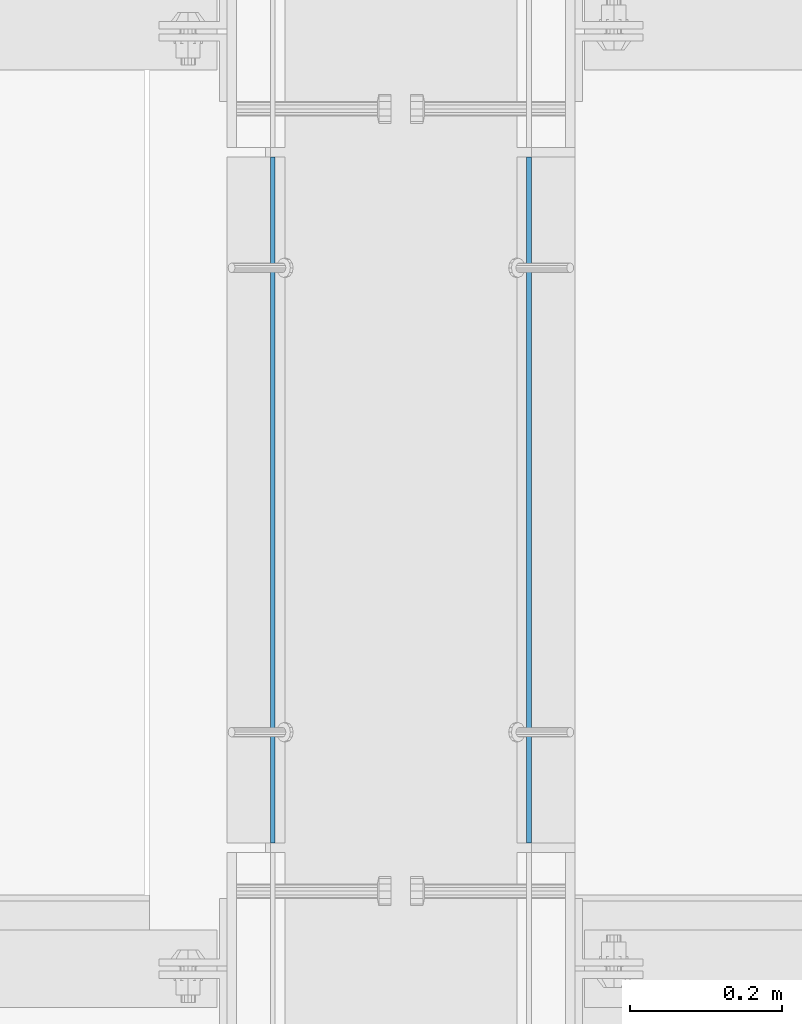
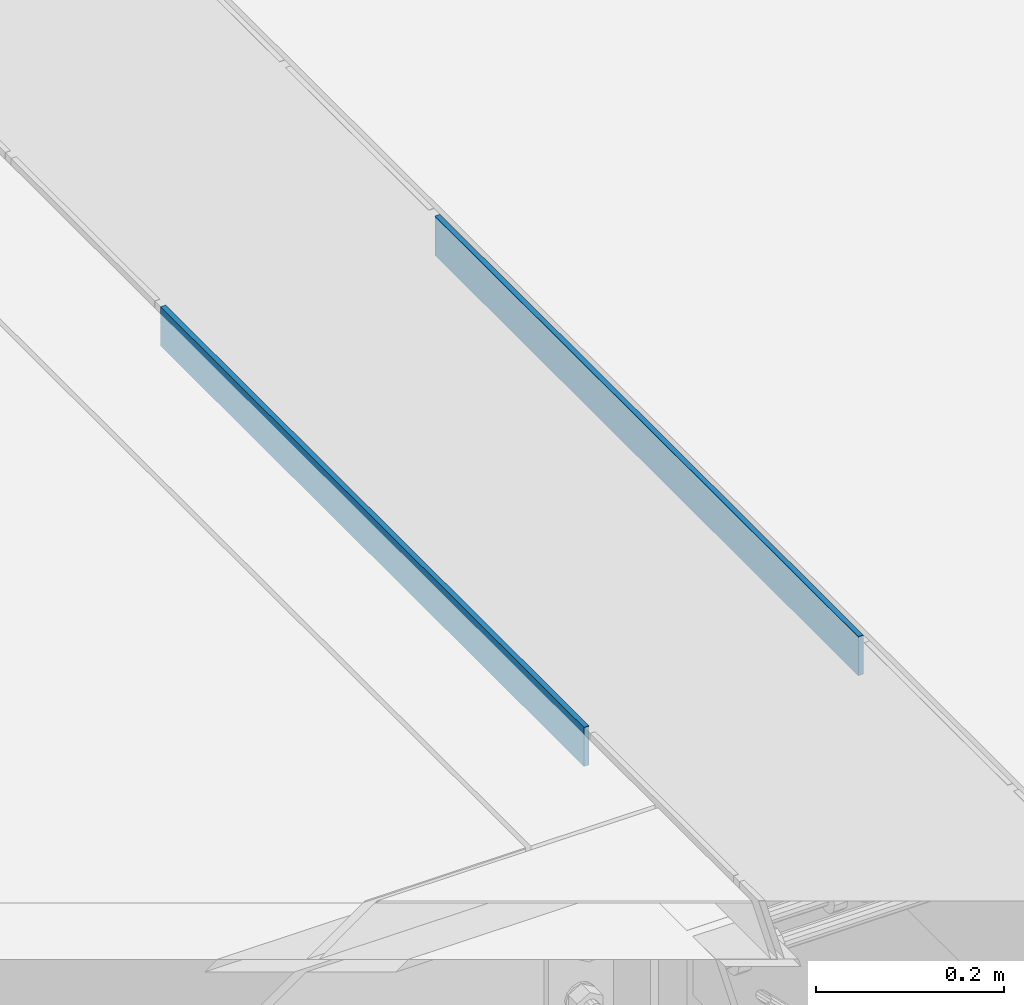
# One storey, part 3066 of 3843: 2 plates, 2 elements without a shape of their own.
"""IFC2X3 building model written with IfcOpenShell, lengths in millimetres."""

from ifc_helpers import new_model, si_unit, frame, origin_with_axes, place, context, subcontext, project, spatial, faceted_brep, material, type_object, element, aggregate, save


model = new_model("IFC2X3")

# Units and contexts
model_context = context("Model", 3, precision=1e-05, world=origin_with_axes())
body_context = subcontext(model_context, "Body", "Model", "MODEL_VIEW")
ifc_project = project(units=[si_unit("LENGTHUNIT", "METRE", prefix="MILLI"), si_unit("AREAUNIT", "SQUARE_METRE"), si_unit("VOLUMEUNIT", "CUBIC_METRE"), si_unit("MASSUNIT", "GRAM", prefix="KILO"), si_unit("TIMEUNIT", "SECOND"), si_unit("PLANEANGLEUNIT", "RADIAN"), si_unit("SOLIDANGLEUNIT", "STERADIAN"), si_unit("THERMODYNAMICTEMPERATUREUNIT", "DEGREE_CELSIUS"), si_unit("LUMINOUSINTENSITYUNIT", "LUMEN")], contexts=[model_context])

# Site, building, storey
site_placement = place(None, origin_with_axes())
site = spatial("IfcSite", under=ifc_project, at=site_placement, CompositionType="ELEMENT")
building_placement = place(site_placement, origin_with_axes())
building = spatial("IfcBuilding", under=site, at=building_placement, Name="Undefined", CompositionType="ELEMENT")
storey_placement = place(building_placement, origin_with_axes())
storey = spatial("IfcBuildingStorey", under=building, at=storey_placement, Name="Undefined", CompositionType="ELEMENT", Elevation=0.0)

# Assembly, plate
assembly_1_placement = place(storey_placement, origin_with_axes())
assembly_1 = element("IfcElementAssembly", 1, at=assembly_1_placement, inside=storey, Name="ANGLE", AssemblyPlace="NOTDEFINED", PredefinedType="RIGID_FRAME")
ifc_material = material(Name="STEEL/A36")
plate_type = type_object("IfcPlateType", PredefinedType="NOTDEFINED")
plate_1_placement = place(assembly_1_placement, frame((59350.2750049347, 15163.7998981715, 30429.2000030518), z_axis=(0.0, 0.999999999997942, -2.02899998962774e-06), x_axis=(0.0, 2.02899999567308e-06, 0.999999999997942)))
plate_1 = element("IfcPlate", 2, at=plate_1_placement, type_object=plate_type, material=ifc_material, Name="PLATE", context=body_context, shape_type="Brep", body=[
    faceted_brep([(0.0, -3.17499999999927, 0.0), (0.00181156927283155, -3.1749999984022, 900.111999510274), (0.00181156927283155, 3.17500000159635, 900.11199951026), (0.0, 3.17499999999927, 0.0), (50.8018112192949, -3.1749999984022, 900.111999510213), (50.8018112192949, 3.17500000159635, 900.111999510198), (50.7999954217848, -3.17499999999563, -7.27595761418343e-12), (50.7999954217848, 3.17500000001019, -1.09139364212751e-11)], [[[0, 1, 2, 3]], [[1, 4, 5, 2]], [[4, 6, 7, 5]], [[6, 0, 3, 7]], [[5, 7, 3, 2]], [[6, 4, 1, 0]]]),
])
aggregate(assembly_1, [plate_1])

assembly_2_placement = place(storey_placement, origin_with_axes())
assembly_2 = element("IfcElementAssembly", 3, at=assembly_2_placement, inside=storey, Name="ANGLE", AssemblyPlace="NOTDEFINED", PredefinedType="RIGID_FRAME")
plate_2_placement = place(assembly_2_placement, frame((59013.7250050932, 15163.800000184, 30429.2000030518), z_axis=(0.0, 0.999999999997942, -2.02899998962774e-06), x_axis=(0.0, 2.02899999567308e-06, 0.999999999997942)))
plate_2 = element("IfcPlate", 4, at=plate_2_placement, type_object=plate_type, material=ifc_material, Name="PLATE", context=body_context, shape_type="Brep", body=[
    faceted_brep([(0.0, -3.17499999999927, 0.0), (0.00181156927283155, -3.1749999984022, 900.111999510274), (0.00181156927283155, 3.17500000159635, 900.11199951026), (0.0, 3.17499999999927, 0.0), (50.8018112192949, -3.1749999984022, 900.111999510213), (50.8018112192949, 3.17500000159635, 900.111999510198), (50.7999954217848, -3.17499999999563, -7.27595761418343e-12), (50.7999954217848, 3.17500000001019, -1.09139364212751e-11)], [[[0, 1, 2, 3]], [[1, 4, 5, 2]], [[4, 6, 7, 5]], [[6, 0, 3, 7]], [[5, 7, 3, 2]], [[6, 4, 1, 0]]]),
])
aggregate(assembly_2, [plate_2])

save(model, "model.ifc")
